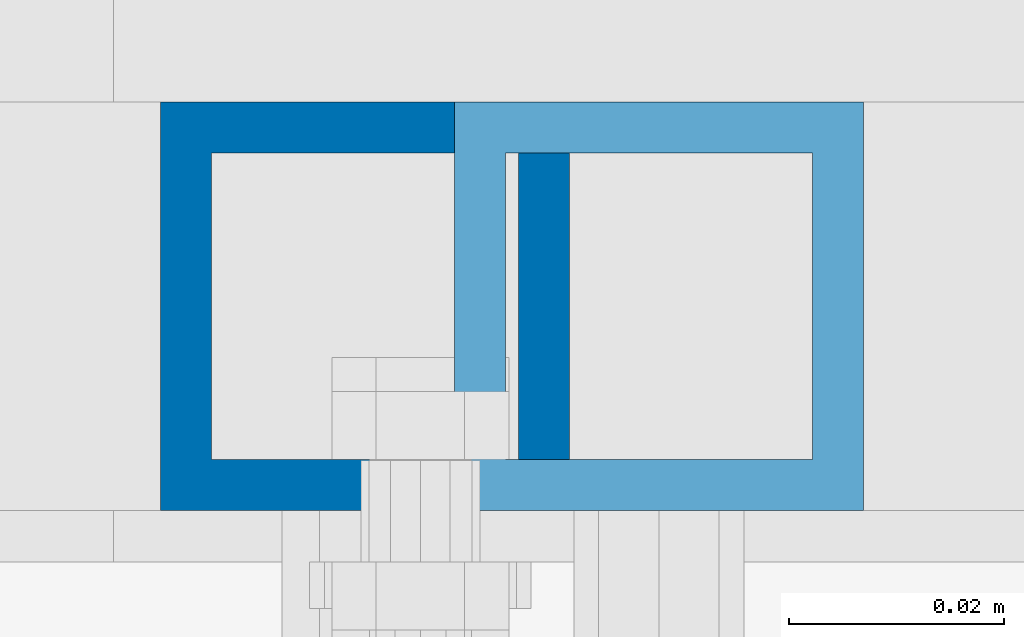
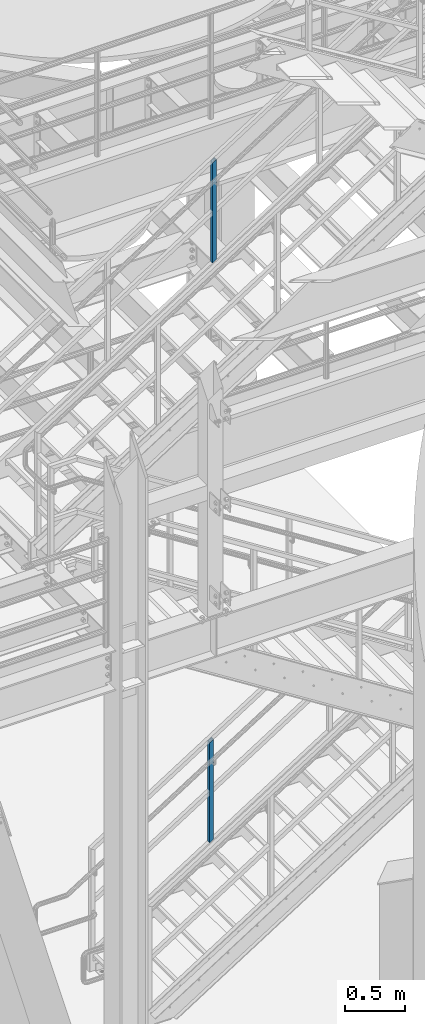
# One storey, part 632 of 1876: 2 columns, 2 elements without a shape of their own.
"""IFC2X3 building model written with IfcOpenShell, lengths in millimetres."""

from ifc_helpers import new_model, si_unit, frame, origin_with_axes, place, context, subcontext, project, spatial, faceted_brep, material, type_object, element, aggregate, save


model = new_model("IFC2X3")

# Units and contexts
model_context = context("Model", 3, precision=1e-05, world=origin_with_axes())
body_context = subcontext(model_context, "Body", "Model", "MODEL_VIEW")
ifc_project = project(units=[si_unit("LENGTHUNIT", "METRE", prefix="MILLI"), si_unit("AREAUNIT", "SQUARE_METRE"), si_unit("VOLUMEUNIT", "CUBIC_METRE"), si_unit("MASSUNIT", "GRAM", prefix="KILO"), si_unit("TIMEUNIT", "SECOND"), si_unit("PLANEANGLEUNIT", "RADIAN"), si_unit("SOLIDANGLEUNIT", "STERADIAN"), si_unit("THERMODYNAMICTEMPERATUREUNIT", "DEGREE_CELSIUS"), si_unit("LUMINOUSINTENSITYUNIT", "LUMEN")], contexts=[model_context])

# Site, building, storey
site_placement = place(None, origin_with_axes())
site = spatial("IfcSite", under=ifc_project, at=site_placement, CompositionType="ELEMENT")
building_placement = place(site_placement, origin_with_axes())
building = spatial("IfcBuilding", under=site, at=building_placement, Name="Undefined", CompositionType="ELEMENT")
storey_placement = place(building_placement, origin_with_axes())
storey = spatial("IfcBuildingStorey", under=building, at=storey_placement, Name="Undefined", CompositionType="ELEMENT", Elevation=0.0)

# Assembly, column
assembly_1_placement = place(storey_placement, origin_with_axes())
assembly_1 = element("IfcElementAssembly", 1, at=assembly_1_placement, inside=storey, Name="RAIL", AssemblyPlace="NOTDEFINED", PredefinedType="RIGID_FRAME")
ifc_material = material()
column_type = type_object("IfcColumnType", Name="HSS1-1/2X1-1/2X3/16", PredefinedType="NOTDEFINED")
column_1_placement = place(assembly_1_placement, frame((3884.21562501345, -4781.55000114554, 931.198079819745), z_axis=(-1.0, 0.0, 0.0), x_axis=(0.0, 0.0, 1.0)))
column_1 = element("IfcColumn", 2, at=column_1_placement, type_object=column_type, material=ifc_material, Name="POST", ObjectType="HSS1-1/2X1-1/2X3/16", context=body_context, shape_type="Brep", body=[
    faceted_brep([(1026.24509902744, -19.0500000000002, -19.0499992349996), (1026.24509902744, 19.0499992349996, -19.0499992349996), (1002.07429278916, 19.0499992349996, 19.0499992349996), (1002.07429278916, -19.0499992349996, 19.0499992349996), (1023.22374824753, -14.2874994260001, -14.2874994260001), (1005.09564356916, -14.2874994260001, 14.2874994260001), (1005.09564356916, 14.2874994260001, 14.2874994260001), (1023.22374824753, 14.2874994260001, -14.2874994260001), (-12.0854031191318, 19.0499992349996, 19.0499992349996), (-12.0854031191318, -19.0499992349996, 19.0499992349996), (12.0854031191295, -19.0499992349996, -19.0499992349996), (12.0854031191295, 19.0499992349996, -19.0499992349996), (-9.06405233919031, 14.2874994260001, 14.2874994260001), (-9.06405233919031, -14.2874994260001, 14.2874994260001), (9.06405233918804, -14.2874994260001, -14.2874994260001), (9.06405233918804, 14.2874994260001, -14.2874994260001)], [[[0, 1, 2, 3], [4, 5, 6, 7]], [[8, 9, 3, 2]], [[9, 10, 0, 3]], [[10, 11, 1, 0]], [[11, 8, 2, 1]], [[10, 9, 8, 11], [12, 13, 14, 15]], [[15, 14, 4, 7]], [[12, 15, 7, 6]], [[13, 12, 6, 5]], [[14, 13, 5, 4]]]),
])
aggregate(assembly_1, [column_1])

assembly_2_placement = place(storey_placement, origin_with_axes())
assembly_2 = element("IfcElementAssembly", 3, at=assembly_2_placement, inside=storey, Name="RAIL", AssemblyPlace="NOTDEFINED", PredefinedType="RIGID_FRAME")
column_2_placement = place(assembly_2_placement, frame((3911.59999717497, -4781.55000114554, 6802.95913170467), z_axis=(-1.0, 0.0, 0.0), x_axis=(0.0, 0.0, 1.0)))
column_2 = element("IfcColumn", 4, at=column_2_placement, type_object=column_type, material=ifc_material, Name="POST", ObjectType="HSS1-1/2X1-1/2X3/16", context=body_context, shape_type="Brep", body=[
    faceted_brep([(1026.23571825648, -19.0500000000002, -19.0499992349996), (1026.23571825648, 19.0499992349996, -19.0499992349996), (1001.99026470106, 19.0499992349996, 19.0499992349996), (1001.99026470106, -19.0499992349996, 19.0499992349996), (1023.20503656197, -14.2874994260001, -14.2874994260001), (1005.02094639574, -14.2874994260001, 14.2874994260001), (1005.02094639574, 14.2874994260001, 14.2874994260001), (1023.20503656197, 14.2874994260001, -14.2874994260001), (-12.1227267776903, 19.0499992349996, 19.0499992349996), (-12.1227267776903, -19.0499992349996, 19.0499992349996), (12.1227267777067, -19.0499992349996, -19.0499992349996), (12.1227267777067, 19.0499992349996, -19.0499992349996), (-9.09204508310631, 14.2874994260001, 14.2874994260001), (-9.09204508310631, -14.2874994260001, 14.2874994260001), (9.09204508312268, -14.2874994260001, -14.2874994260001), (9.09204508312268, 14.2874994260001, -14.2874994260001)], [[[0, 1, 2, 3], [4, 5, 6, 7]], [[8, 9, 3, 2]], [[9, 10, 0, 3]], [[10, 11, 1, 0]], [[11, 8, 2, 1]], [[10, 9, 8, 11], [12, 13, 14, 15]], [[15, 14, 4, 7]], [[12, 15, 7, 6]], [[13, 12, 6, 5]], [[14, 13, 5, 4]]]),
])
aggregate(assembly_2, [column_2])

save(model, "model.ifc")
